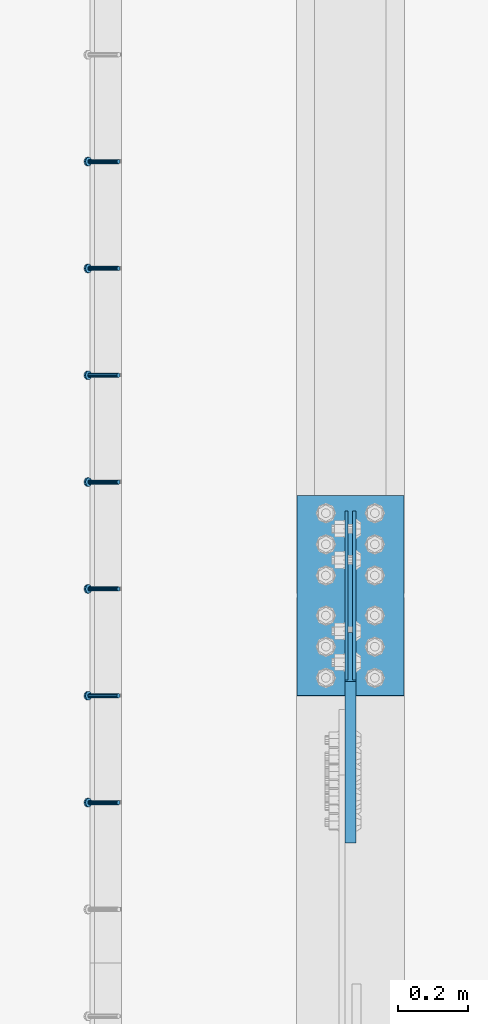
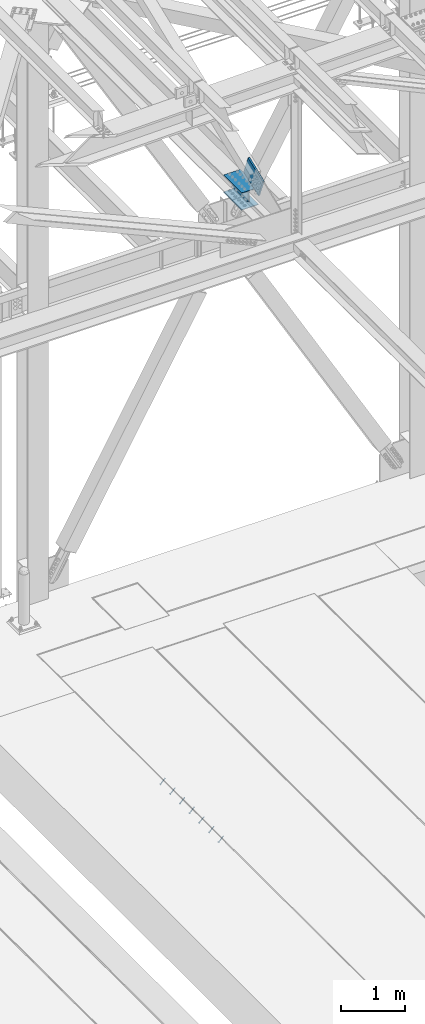
# One storey, part 2482 of 3843: 8 members, 4 beams, 3 elements without a shape of their own.
"""IFC2X3 building model written with IfcOpenShell, lengths in millimetres."""

from ifc_helpers import new_model, si_unit, frame, origin_with_axes, place, context, subcontext, project, spatial, faceted_brep, material, type_object, element, aggregate, save


model = new_model("IFC2X3")

# Units and contexts
model_context = context("Model", 3, precision=1e-05, world=origin_with_axes())
body_context = subcontext(model_context, "Body", "Model", "MODEL_VIEW")
ifc_project = project(units=[si_unit("LENGTHUNIT", "METRE", prefix="MILLI"), si_unit("AREAUNIT", "SQUARE_METRE"), si_unit("VOLUMEUNIT", "CUBIC_METRE"), si_unit("MASSUNIT", "GRAM", prefix="KILO"), si_unit("TIMEUNIT", "SECOND"), si_unit("PLANEANGLEUNIT", "RADIAN"), si_unit("SOLIDANGLEUNIT", "STERADIAN"), si_unit("THERMODYNAMICTEMPERATUREUNIT", "DEGREE_CELSIUS"), si_unit("LUMINOUSINTENSITYUNIT", "LUMEN")], contexts=[model_context])

# Site, building, storey
site_placement = place(None, origin_with_axes())
site = spatial("IfcSite", under=ifc_project, at=site_placement, CompositionType="ELEMENT")
building_placement = place(site_placement, origin_with_axes())
building = spatial("IfcBuilding", under=site, at=building_placement, Name="Undefined", CompositionType="ELEMENT")
storey_placement = place(building_placement, origin_with_axes())
storey = spatial("IfcBuildingStorey", under=building, at=storey_placement, Name="Undefined", CompositionType="ELEMENT", Elevation=0.0)

# Assembly, members
assembly_1_placement = place(storey_placement, origin_with_axes())
assembly_1 = element("IfcElementAssembly", 1, at=assembly_1_placement, inside=storey, Name="EMBED_ANGLE", AssemblyPlace="NOTDEFINED", PredefinedType="RIGID_FRAME")
ifc_material_1 = material(Name="STEEL/A108")
member_type_1 = type_object("IfcMemberType", PredefinedType="NOTDEFINED")
member_1_placement = place(assembly_1_placement, frame((48335.3741210938, 85070.8232116699, 30446.6625), z_axis=(0.0, -1.0, 0.0), x_axis=(-0.707106781186548, 0.0, -0.707106781186548)))
member_1 = element("IfcMember", 2, at=member_1_placement, type_object=member_type_1, material=ifc_material_1, Name="HEADED STUD ANCHOR", context=body_context, shape_type="Brep", body=[
    faceted_brep([(7.27595761418343e-12, -3.18000006675175, 5.5), (0.0, -5.49999999998363, 3.1800000667572), (118.110000000976, -5.49999999999091, 3.1800000667572), (118.110000000983, -3.18000006675175, 5.5), (0.0, -6.3499999046162, 0.0), (118.110000000968, -6.34999990461256, 0.0), (0.0, -5.49999999998363, -3.1800000667572), (118.110000000976, -5.49999999999091, -3.1800000667572), (7.27595761418343e-12, -3.18000006675175, -5.5), (118.110000000983, -3.18000006675175, -5.5), (7.27595761418343e-12, -1.81898940354586e-12, -6.34999990463257), (118.110000000968, -1.81898940354586e-12, -6.34999990463257), (0.0, 3.18000006675175, -5.5), (118.110000000968, 3.18000006674811, -5.5), (7.27595761418343e-12, 5.49999999998363, -3.1800000667572), (118.110000000983, 5.49999999998363, -3.1800000667572), (7.27595761418343e-12, 6.3499999046162, 0.0), (118.110000000976, 6.34999990461256, 0.0), (7.27595761418343e-12, 5.49999999998363, 3.1800000667572), (118.110000000983, 5.49999999998363, 3.1800000667572), (0.0, 3.18000006675175, 5.5), (118.110000000968, 3.18000006674811, 5.5), (7.27595761418343e-12, -1.81898940354586e-12, 6.34999990463257), (118.110000000968, -1.81898940354586e-12, 6.34999990463257), (120.650000000991, -10.9899997710909, 6.34999990463257), (120.650000000998, -6.34000015257152, 10.9899997711182), (120.650000000991, -12.6999998092379, 0.0), (120.650000000991, -10.9899997710909, -6.34999990463257), (120.650000000998, -6.34000015257152, -10.9899997711182), (120.650000000991, -1.81898940354586e-12, -12.6899995803833), (120.650000000991, 6.34000015257152, -10.9899997711182), (120.650000000998, 10.9899997710909, -6.34999990463257), (120.650000000991, 12.6999998092342, 0.0), (120.650000000998, 10.9899997710909, 6.34999990463257), (120.650000000991, 6.34000015257152, 10.9899997711182), (120.650000000991, -1.81898940354586e-12, 12.6899995803833), (127.000000001048, -10.9899997710945, 6.34999990463257), (127.000000001048, -6.34000015257152, 10.9899997711182), (127.000000001048, -12.6999998092342, 0.0), (127.000000001048, -10.9899997710945, -6.34999990463257), (127.000000001048, -6.34000015257152, -10.9899997711182), (127.000000001048, 1.81898940354586e-12, -12.6899995803833), (127.000000001048, 6.34000015256788, -10.9899997711182), (127.000000001048, 10.9899997710909, -6.34999990463257), (127.000000001048, 12.6999998092379, 0.0), (127.000000001048, 10.9899997710909, 6.34999990463257), (127.000000001048, 6.34000015256788, 10.9899997711182), (127.000000001048, 1.81898940354586e-12, 12.6899995803833)], [[[0, 1, 2, 3]], [[1, 4, 5, 2]], [[4, 6, 7, 5]], [[6, 8, 9, 7]], [[8, 10, 11, 9]], [[10, 12, 13, 11]], [[12, 14, 15, 13]], [[14, 16, 17, 15]], [[16, 18, 19, 17]], [[18, 20, 21, 19]], [[20, 22, 23, 21]], [[22, 0, 3, 23]], [[22, 20, 18, 16, 14, 12, 10, 8, 6, 4, 1, 0]], [[3, 2, 24, 25]], [[2, 5, 26, 24]], [[5, 7, 27, 26]], [[7, 9, 28, 27]], [[9, 11, 29, 28]], [[11, 13, 30, 29]], [[13, 15, 31, 30]], [[15, 17, 32, 31]], [[17, 19, 33, 32]], [[19, 21, 34, 33]], [[21, 23, 35, 34]], [[23, 3, 25, 35]], [[25, 24, 36, 37]], [[24, 26, 38, 36]], [[26, 27, 39, 38]], [[27, 28, 40, 39]], [[28, 29, 41, 40]], [[29, 30, 42, 41]], [[30, 31, 43, 42]], [[31, 32, 44, 43]], [[32, 33, 45, 44]], [[33, 34, 46, 45]], [[34, 35, 47, 46]], [[35, 25, 37, 47]], [[38, 39, 40, 41, 42, 43, 44, 45, 46, 47, 37, 36]]]),
])
member_2_placement = place(assembly_1_placement, frame((48335.3741210938, 85375.6232116699, 30446.6625), z_axis=(0.0, -1.0, 0.0), x_axis=(-0.707106781186548, 0.0, -0.707106781186548)))
member_2 = element("IfcMember", 3, at=member_2_placement, type_object=member_type_1, material=ifc_material_1, Name="HEADED STUD ANCHOR", context=body_context, shape_type="Brep", body=[
    faceted_brep([(7.27595761418343e-12, -3.18000006675175, 5.5), (0.0, -5.49999999998363, 3.1800000667572), (118.110000000976, -5.49999999999091, 3.1800000667572), (118.110000000983, -3.18000006675175, 5.5), (0.0, -6.3499999046162, 0.0), (118.110000000968, -6.34999990461256, 0.0), (0.0, -5.49999999998363, -3.1800000667572), (118.110000000976, -5.49999999999091, -3.1800000667572), (7.27595761418343e-12, -3.18000006675175, -5.5), (118.110000000983, -3.18000006675175, -5.5), (7.27595761418343e-12, -1.81898940354586e-12, -6.34999990463257), (118.110000000968, -1.81898940354586e-12, -6.34999990463257), (0.0, 3.18000006675175, -5.5), (118.110000000968, 3.18000006674811, -5.5), (7.27595761418343e-12, 5.49999999998363, -3.1800000667572), (118.110000000983, 5.49999999998363, -3.1800000667572), (7.27595761418343e-12, 6.3499999046162, 0.0), (118.110000000976, 6.34999990461256, 0.0), (7.27595761418343e-12, 5.49999999998363, 3.1800000667572), (118.110000000983, 5.49999999998363, 3.1800000667572), (0.0, 3.18000006675175, 5.5), (118.110000000968, 3.18000006674811, 5.5), (7.27595761418343e-12, -1.81898940354586e-12, 6.34999990463257), (118.110000000968, -1.81898940354586e-12, 6.34999990463257), (120.650000000991, -10.9899997710909, 6.34999990463257), (120.650000000998, -6.34000015257152, 10.9899997711182), (120.650000000991, -12.6999998092379, 0.0), (120.650000000991, -10.9899997710909, -6.34999990463257), (120.650000000998, -6.34000015257152, -10.9899997711182), (120.650000000991, -1.81898940354586e-12, -12.6899995803833), (120.650000000991, 6.34000015257152, -10.9899997711182), (120.650000000998, 10.9899997710909, -6.34999990463257), (120.650000000991, 12.6999998092342, 0.0), (120.650000000998, 10.9899997710909, 6.34999990463257), (120.650000000991, 6.34000015257152, 10.9899997711182), (120.650000000991, -1.81898940354586e-12, 12.6899995803833), (127.000000001048, -10.9899997710945, 6.34999990463257), (127.000000001048, -6.34000015257152, 10.9899997711182), (127.000000001048, -12.6999998092342, 0.0), (127.000000001048, -10.9899997710945, -6.34999990463257), (127.000000001048, -6.34000015257152, -10.9899997711182), (127.000000001048, 1.81898940354586e-12, -12.6899995803833), (127.000000001048, 6.34000015256788, -10.9899997711182), (127.000000001048, 10.9899997710909, -6.34999990463257), (127.000000001048, 12.6999998092379, 0.0), (127.000000001048, 10.9899997710909, 6.34999990463257), (127.000000001048, 6.34000015256788, 10.9899997711182), (127.000000001048, 1.81898940354586e-12, 12.6899995803833)], [[[0, 1, 2, 3]], [[1, 4, 5, 2]], [[4, 6, 7, 5]], [[6, 8, 9, 7]], [[8, 10, 11, 9]], [[10, 12, 13, 11]], [[12, 14, 15, 13]], [[14, 16, 17, 15]], [[16, 18, 19, 17]], [[18, 20, 21, 19]], [[20, 22, 23, 21]], [[22, 0, 3, 23]], [[22, 20, 18, 16, 14, 12, 10, 8, 6, 4, 1, 0]], [[3, 2, 24, 25]], [[2, 5, 26, 24]], [[5, 7, 27, 26]], [[7, 9, 28, 27]], [[9, 11, 29, 28]], [[11, 13, 30, 29]], [[13, 15, 31, 30]], [[15, 17, 32, 31]], [[17, 19, 33, 32]], [[19, 21, 34, 33]], [[21, 23, 35, 34]], [[23, 3, 25, 35]], [[25, 24, 36, 37]], [[24, 26, 38, 36]], [[26, 27, 39, 38]], [[27, 28, 40, 39]], [[28, 29, 41, 40]], [[29, 30, 42, 41]], [[30, 31, 43, 42]], [[31, 32, 44, 43]], [[32, 33, 45, 44]], [[33, 34, 46, 45]], [[34, 35, 47, 46]], [[35, 25, 37, 47]], [[38, 39, 40, 41, 42, 43, 44, 45, 46, 47, 37, 36]]]),
])
member_3_placement = place(assembly_1_placement, frame((48335.3741210938, 85680.4232116699, 30446.6625), z_axis=(0.0, -1.0, 0.0), x_axis=(-0.707106781186548, 0.0, -0.707106781186548)))
member_3 = element("IfcMember", 4, at=member_3_placement, type_object=member_type_1, material=ifc_material_1, Name="HEADED STUD ANCHOR", context=body_context, shape_type="Brep", body=[
    faceted_brep([(7.27595761418343e-12, -3.18000006675175, 5.5), (0.0, -5.49999999998363, 3.1800000667572), (118.110000000976, -5.49999999999091, 3.1800000667572), (118.110000000983, -3.18000006675175, 5.5), (0.0, -6.3499999046162, 0.0), (118.110000000968, -6.34999990461256, 0.0), (0.0, -5.49999999998363, -3.1800000667572), (118.110000000976, -5.49999999999091, -3.1800000667572), (7.27595761418343e-12, -3.18000006675175, -5.5), (118.110000000983, -3.18000006675175, -5.5), (7.27595761418343e-12, -1.81898940354586e-12, -6.34999990463257), (118.110000000968, -1.81898940354586e-12, -6.34999990463257), (0.0, 3.18000006675175, -5.5), (118.110000000968, 3.18000006674811, -5.5), (7.27595761418343e-12, 5.49999999998363, -3.1800000667572), (118.110000000983, 5.49999999998363, -3.1800000667572), (7.27595761418343e-12, 6.3499999046162, 0.0), (118.110000000976, 6.34999990461256, 0.0), (7.27595761418343e-12, 5.49999999998363, 3.1800000667572), (118.110000000983, 5.49999999998363, 3.1800000667572), (0.0, 3.18000006675175, 5.5), (118.110000000968, 3.18000006674811, 5.5), (7.27595761418343e-12, -1.81898940354586e-12, 6.34999990463257), (118.110000000968, -1.81898940354586e-12, 6.34999990463257), (120.650000000991, -10.9899997710909, 6.34999990463257), (120.650000000998, -6.34000015257152, 10.9899997711182), (120.650000000991, -12.6999998092379, 0.0), (120.650000000991, -10.9899997710909, -6.34999990463257), (120.650000000998, -6.34000015257152, -10.9899997711182), (120.650000000991, -1.81898940354586e-12, -12.6899995803833), (120.650000000991, 6.34000015257152, -10.9899997711182), (120.650000000998, 10.9899997710909, -6.34999990463257), (120.650000000991, 12.6999998092342, 0.0), (120.650000000998, 10.9899997710909, 6.34999990463257), (120.650000000991, 6.34000015257152, 10.9899997711182), (120.650000000991, -1.81898940354586e-12, 12.6899995803833), (127.000000001048, -10.9899997710945, 6.34999990463257), (127.000000001048, -6.34000015257152, 10.9899997711182), (127.000000001048, -12.6999998092342, 0.0), (127.000000001048, -10.9899997710945, -6.34999990463257), (127.000000001048, -6.34000015257152, -10.9899997711182), (127.000000001048, 1.81898940354586e-12, -12.6899995803833), (127.000000001048, 6.34000015256788, -10.9899997711182), (127.000000001048, 10.9899997710909, -6.34999990463257), (127.000000001048, 12.6999998092379, 0.0), (127.000000001048, 10.9899997710909, 6.34999990463257), (127.000000001048, 6.34000015256788, 10.9899997711182), (127.000000001048, 1.81898940354586e-12, 12.6899995803833)], [[[0, 1, 2, 3]], [[1, 4, 5, 2]], [[4, 6, 7, 5]], [[6, 8, 9, 7]], [[8, 10, 11, 9]], [[10, 12, 13, 11]], [[12, 14, 15, 13]], [[14, 16, 17, 15]], [[16, 18, 19, 17]], [[18, 20, 21, 19]], [[20, 22, 23, 21]], [[22, 0, 3, 23]], [[22, 20, 18, 16, 14, 12, 10, 8, 6, 4, 1, 0]], [[3, 2, 24, 25]], [[2, 5, 26, 24]], [[5, 7, 27, 26]], [[7, 9, 28, 27]], [[9, 11, 29, 28]], [[11, 13, 30, 29]], [[13, 15, 31, 30]], [[15, 17, 32, 31]], [[17, 19, 33, 32]], [[19, 21, 34, 33]], [[21, 23, 35, 34]], [[23, 3, 25, 35]], [[25, 24, 36, 37]], [[24, 26, 38, 36]], [[26, 27, 39, 38]], [[27, 28, 40, 39]], [[28, 29, 41, 40]], [[29, 30, 42, 41]], [[30, 31, 43, 42]], [[31, 32, 44, 43]], [[32, 33, 45, 44]], [[33, 34, 46, 45]], [[34, 35, 47, 46]], [[35, 25, 37, 47]], [[38, 39, 40, 41, 42, 43, 44, 45, 46, 47, 37, 36]]]),
])
member_4_placement = place(assembly_1_placement, frame((48335.3741210938, 85985.2232116699, 30446.6625), z_axis=(0.0, -1.0, 0.0), x_axis=(-0.707106781186548, 0.0, -0.707106781186548)))
member_4 = element("IfcMember", 5, at=member_4_placement, type_object=member_type_1, material=ifc_material_1, Name="HEADED STUD ANCHOR", context=body_context, shape_type="Brep", body=[
    faceted_brep([(7.27595761418343e-12, -3.18000006675175, 5.5), (0.0, -5.49999999998363, 3.1800000667572), (118.110000000976, -5.49999999999091, 3.1800000667572), (118.110000000983, -3.18000006675175, 5.5), (0.0, -6.3499999046162, 0.0), (118.110000000968, -6.34999990461256, 0.0), (0.0, -5.49999999998363, -3.1800000667572), (118.110000000976, -5.49999999999091, -3.1800000667572), (7.27595761418343e-12, -3.18000006675175, -5.5), (118.110000000983, -3.18000006675175, -5.5), (7.27595761418343e-12, -1.81898940354586e-12, -6.34999990463257), (118.110000000968, -1.81898940354586e-12, -6.34999990463257), (0.0, 3.18000006675175, -5.5), (118.110000000968, 3.18000006674811, -5.5), (7.27595761418343e-12, 5.49999999998363, -3.1800000667572), (118.110000000983, 5.49999999998363, -3.1800000667572), (7.27595761418343e-12, 6.3499999046162, 0.0), (118.110000000976, 6.34999990461256, 0.0), (7.27595761418343e-12, 5.49999999998363, 3.1800000667572), (118.110000000983, 5.49999999998363, 3.1800000667572), (0.0, 3.18000006675175, 5.5), (118.110000000968, 3.18000006674811, 5.5), (7.27595761418343e-12, -1.81898940354586e-12, 6.34999990463257), (118.110000000968, -1.81898940354586e-12, 6.34999990463257), (120.650000000991, -10.9899997710909, 6.34999990463257), (120.650000000998, -6.34000015257152, 10.9899997711182), (120.650000000991, -12.6999998092379, 0.0), (120.650000000991, -10.9899997710909, -6.34999990463257), (120.650000000998, -6.34000015257152, -10.9899997711182), (120.650000000991, -1.81898940354586e-12, -12.6899995803833), (120.650000000991, 6.34000015257152, -10.9899997711182), (120.650000000998, 10.9899997710909, -6.34999990463257), (120.650000000991, 12.6999998092342, 0.0), (120.650000000998, 10.9899997710909, 6.34999990463257), (120.650000000991, 6.34000015257152, 10.9899997711182), (120.650000000991, -1.81898940354586e-12, 12.6899995803833), (127.000000001048, -10.9899997710945, 6.34999990463257), (127.000000001048, -6.34000015257152, 10.9899997711182), (127.000000001048, -12.6999998092342, 0.0), (127.000000001048, -10.9899997710945, -6.34999990463257), (127.000000001048, -6.34000015257152, -10.9899997711182), (127.000000001048, 1.81898940354586e-12, -12.6899995803833), (127.000000001048, 6.34000015256788, -10.9899997711182), (127.000000001048, 10.9899997710909, -6.34999990463257), (127.000000001048, 12.6999998092379, 0.0), (127.000000001048, 10.9899997710909, 6.34999990463257), (127.000000001048, 6.34000015256788, 10.9899997711182), (127.000000001048, 1.81898940354586e-12, 12.6899995803833)], [[[0, 1, 2, 3]], [[1, 4, 5, 2]], [[4, 6, 7, 5]], [[6, 8, 9, 7]], [[8, 10, 11, 9]], [[10, 12, 13, 11]], [[12, 14, 15, 13]], [[14, 16, 17, 15]], [[16, 18, 19, 17]], [[18, 20, 21, 19]], [[20, 22, 23, 21]], [[22, 0, 3, 23]], [[22, 20, 18, 16, 14, 12, 10, 8, 6, 4, 1, 0]], [[3, 2, 24, 25]], [[2, 5, 26, 24]], [[5, 7, 27, 26]], [[7, 9, 28, 27]], [[9, 11, 29, 28]], [[11, 13, 30, 29]], [[13, 15, 31, 30]], [[15, 17, 32, 31]], [[17, 19, 33, 32]], [[19, 21, 34, 33]], [[21, 23, 35, 34]], [[23, 3, 25, 35]], [[25, 24, 36, 37]], [[24, 26, 38, 36]], [[26, 27, 39, 38]], [[27, 28, 40, 39]], [[28, 29, 41, 40]], [[29, 30, 42, 41]], [[30, 31, 43, 42]], [[31, 32, 44, 43]], [[32, 33, 45, 44]], [[33, 34, 46, 45]], [[34, 35, 47, 46]], [[35, 25, 37, 47]], [[38, 39, 40, 41, 42, 43, 44, 45, 46, 47, 37, 36]]]),
])
member_5_placement = place(assembly_1_placement, frame((48335.3741210938, 86290.0232116699, 30446.6625), z_axis=(0.0, -1.0, 0.0), x_axis=(-0.707106781186548, 0.0, -0.707106781186548)))
member_5 = element("IfcMember", 6, at=member_5_placement, type_object=member_type_1, material=ifc_material_1, Name="HEADED STUD ANCHOR", context=body_context, shape_type="Brep", body=[
    faceted_brep([(7.27595761418343e-12, -3.18000006675175, 5.5), (0.0, -5.49999999998363, 3.1800000667572), (118.110000000976, -5.49999999999091, 3.1800000667572), (118.110000000983, -3.18000006675175, 5.5), (0.0, -6.3499999046162, 0.0), (118.110000000968, -6.34999990461256, 0.0), (0.0, -5.49999999998363, -3.1800000667572), (118.110000000976, -5.49999999999091, -3.1800000667572), (7.27595761418343e-12, -3.18000006675175, -5.5), (118.110000000983, -3.18000006675175, -5.5), (7.27595761418343e-12, -1.81898940354586e-12, -6.34999990463257), (118.110000000968, -1.81898940354586e-12, -6.34999990463257), (0.0, 3.18000006675175, -5.5), (118.110000000968, 3.18000006674811, -5.5), (7.27595761418343e-12, 5.49999999998363, -3.1800000667572), (118.110000000983, 5.49999999998363, -3.1800000667572), (7.27595761418343e-12, 6.3499999046162, 0.0), (118.110000000976, 6.34999990461256, 0.0), (7.27595761418343e-12, 5.49999999998363, 3.1800000667572), (118.110000000983, 5.49999999998363, 3.1800000667572), (0.0, 3.18000006675175, 5.5), (118.110000000968, 3.18000006674811, 5.5), (7.27595761418343e-12, -1.81898940354586e-12, 6.34999990463257), (118.110000000968, -1.81898940354586e-12, 6.34999990463257), (120.650000000991, -10.9899997710909, 6.34999990463257), (120.650000000998, -6.34000015257152, 10.9899997711182), (120.650000000991, -12.6999998092379, 0.0), (120.650000000991, -10.9899997710909, -6.34999990463257), (120.650000000998, -6.34000015257152, -10.9899997711182), (120.650000000991, -1.81898940354586e-12, -12.6899995803833), (120.650000000991, 6.34000015257152, -10.9899997711182), (120.650000000998, 10.9899997710909, -6.34999990463257), (120.650000000991, 12.6999998092342, 0.0), (120.650000000998, 10.9899997710909, 6.34999990463257), (120.650000000991, 6.34000015257152, 10.9899997711182), (120.650000000991, -1.81898940354586e-12, 12.6899995803833), (127.000000001048, -10.9899997710945, 6.34999990463257), (127.000000001048, -6.34000015257152, 10.9899997711182), (127.000000001048, -12.6999998092342, 0.0), (127.000000001048, -10.9899997710945, -6.34999990463257), (127.000000001048, -6.34000015257152, -10.9899997711182), (127.000000001048, 1.81898940354586e-12, -12.6899995803833), (127.000000001048, 6.34000015256788, -10.9899997711182), (127.000000001048, 10.9899997710909, -6.34999990463257), (127.000000001048, 12.6999998092379, 0.0), (127.000000001048, 10.9899997710909, 6.34999990463257), (127.000000001048, 6.34000015256788, 10.9899997711182), (127.000000001048, 1.81898940354586e-12, 12.6899995803833)], [[[0, 1, 2, 3]], [[1, 4, 5, 2]], [[4, 6, 7, 5]], [[6, 8, 9, 7]], [[8, 10, 11, 9]], [[10, 12, 13, 11]], [[12, 14, 15, 13]], [[14, 16, 17, 15]], [[16, 18, 19, 17]], [[18, 20, 21, 19]], [[20, 22, 23, 21]], [[22, 0, 3, 23]], [[22, 20, 18, 16, 14, 12, 10, 8, 6, 4, 1, 0]], [[3, 2, 24, 25]], [[2, 5, 26, 24]], [[5, 7, 27, 26]], [[7, 9, 28, 27]], [[9, 11, 29, 28]], [[11, 13, 30, 29]], [[13, 15, 31, 30]], [[15, 17, 32, 31]], [[17, 19, 33, 32]], [[19, 21, 34, 33]], [[21, 23, 35, 34]], [[23, 3, 25, 35]], [[25, 24, 36, 37]], [[24, 26, 38, 36]], [[26, 27, 39, 38]], [[27, 28, 40, 39]], [[28, 29, 41, 40]], [[29, 30, 42, 41]], [[30, 31, 43, 42]], [[31, 32, 44, 43]], [[32, 33, 45, 44]], [[33, 34, 46, 45]], [[34, 35, 47, 46]], [[35, 25, 37, 47]], [[38, 39, 40, 41, 42, 43, 44, 45, 46, 47, 37, 36]]]),
])
member_6_placement = place(assembly_1_placement, frame((48335.3741210938, 86594.8232116699, 30446.6625), z_axis=(0.0, -1.0, 0.0), x_axis=(-0.707106781186548, 0.0, -0.707106781186548)))
member_6 = element("IfcMember", 7, at=member_6_placement, type_object=member_type_1, material=ifc_material_1, Name="HEADED STUD ANCHOR", context=body_context, shape_type="Brep", body=[
    faceted_brep([(7.27595761418343e-12, -3.18000006675175, 5.5), (0.0, -5.49999999998363, 3.1800000667572), (118.110000000976, -5.49999999999091, 3.1800000667572), (118.110000000983, -3.18000006675175, 5.5), (0.0, -6.3499999046162, 0.0), (118.110000000968, -6.34999990461256, 0.0), (0.0, -5.49999999998363, -3.1800000667572), (118.110000000976, -5.49999999999091, -3.1800000667572), (7.27595761418343e-12, -3.18000006675175, -5.5), (118.110000000983, -3.18000006675175, -5.5), (7.27595761418343e-12, -1.81898940354586e-12, -6.34999990463257), (118.110000000968, -1.81898940354586e-12, -6.34999990463257), (0.0, 3.18000006675175, -5.5), (118.110000000968, 3.18000006674811, -5.5), (7.27595761418343e-12, 5.49999999998363, -3.1800000667572), (118.110000000983, 5.49999999998363, -3.1800000667572), (7.27595761418343e-12, 6.3499999046162, 0.0), (118.110000000976, 6.34999990461256, 0.0), (7.27595761418343e-12, 5.49999999998363, 3.1800000667572), (118.110000000983, 5.49999999998363, 3.1800000667572), (0.0, 3.18000006675175, 5.5), (118.110000000968, 3.18000006674811, 5.5), (7.27595761418343e-12, -1.81898940354586e-12, 6.34999990463257), (118.110000000968, -1.81898940354586e-12, 6.34999990463257), (120.650000000991, -10.9899997710909, 6.34999990463257), (120.650000000998, -6.34000015257152, 10.9899997711182), (120.650000000991, -12.6999998092379, 0.0), (120.650000000991, -10.9899997710909, -6.34999990463257), (120.650000000998, -6.34000015257152, -10.9899997711182), (120.650000000991, -1.81898940354586e-12, -12.6899995803833), (120.650000000991, 6.34000015257152, -10.9899997711182), (120.650000000998, 10.9899997710909, -6.34999990463257), (120.650000000991, 12.6999998092342, 0.0), (120.650000000998, 10.9899997710909, 6.34999990463257), (120.650000000991, 6.34000015257152, 10.9899997711182), (120.650000000991, -1.81898940354586e-12, 12.6899995803833), (127.000000001048, -10.9899997710945, 6.34999990463257), (127.000000001048, -6.34000015257152, 10.9899997711182), (127.000000001048, -12.6999998092342, 0.0), (127.000000001048, -10.9899997710945, -6.34999990463257), (127.000000001048, -6.34000015257152, -10.9899997711182), (127.000000001048, 1.81898940354586e-12, -12.6899995803833), (127.000000001048, 6.34000015256788, -10.9899997711182), (127.000000001048, 10.9899997710909, -6.34999990463257), (127.000000001048, 12.6999998092379, 0.0), (127.000000001048, 10.9899997710909, 6.34999990463257), (127.000000001048, 6.34000015256788, 10.9899997711182), (127.000000001048, 1.81898940354586e-12, 12.6899995803833)], [[[0, 1, 2, 3]], [[1, 4, 5, 2]], [[4, 6, 7, 5]], [[6, 8, 9, 7]], [[8, 10, 11, 9]], [[10, 12, 13, 11]], [[12, 14, 15, 13]], [[14, 16, 17, 15]], [[16, 18, 19, 17]], [[18, 20, 21, 19]], [[20, 22, 23, 21]], [[22, 0, 3, 23]], [[22, 20, 18, 16, 14, 12, 10, 8, 6, 4, 1, 0]], [[3, 2, 24, 25]], [[2, 5, 26, 24]], [[5, 7, 27, 26]], [[7, 9, 28, 27]], [[9, 11, 29, 28]], [[11, 13, 30, 29]], [[13, 15, 31, 30]], [[15, 17, 32, 31]], [[17, 19, 33, 32]], [[19, 21, 34, 33]], [[21, 23, 35, 34]], [[23, 3, 25, 35]], [[25, 24, 36, 37]], [[24, 26, 38, 36]], [[26, 27, 39, 38]], [[27, 28, 40, 39]], [[28, 29, 41, 40]], [[29, 30, 42, 41]], [[30, 31, 43, 42]], [[31, 32, 44, 43]], [[32, 33, 45, 44]], [[33, 34, 46, 45]], [[34, 35, 47, 46]], [[35, 25, 37, 47]], [[38, 39, 40, 41, 42, 43, 44, 45, 46, 47, 37, 36]]]),
])
member_7_placement = place(assembly_1_placement, frame((48335.3741210938, 86899.6232116699, 30446.6625), z_axis=(0.0, -1.0, 0.0), x_axis=(-0.707106781186548, 0.0, -0.707106781186548)))
member_7 = element("IfcMember", 8, at=member_7_placement, type_object=member_type_1, material=ifc_material_1, Name="HEADED STUD ANCHOR", context=body_context, shape_type="Brep", body=[
    faceted_brep([(7.27595761418343e-12, -3.18000006675175, 5.5), (0.0, -5.49999999998363, 3.1800000667572), (118.110000000976, -5.49999999999091, 3.1800000667572), (118.110000000983, -3.18000006675175, 5.5), (0.0, -6.3499999046162, 0.0), (118.110000000968, -6.34999990461256, 0.0), (0.0, -5.49999999998363, -3.1800000667572), (118.110000000976, -5.49999999999091, -3.1800000667572), (7.27595761418343e-12, -3.18000006675175, -5.5), (118.110000000983, -3.18000006675175, -5.5), (7.27595761418343e-12, -1.81898940354586e-12, -6.34999990463257), (118.110000000968, -1.81898940354586e-12, -6.34999990463257), (0.0, 3.18000006675175, -5.5), (118.110000000968, 3.18000006674811, -5.5), (7.27595761418343e-12, 5.49999999998363, -3.1800000667572), (118.110000000983, 5.49999999998363, -3.1800000667572), (7.27595761418343e-12, 6.3499999046162, 0.0), (118.110000000976, 6.34999990461256, 0.0), (7.27595761418343e-12, 5.49999999998363, 3.1800000667572), (118.110000000983, 5.49999999998363, 3.1800000667572), (0.0, 3.18000006675175, 5.5), (118.110000000968, 3.18000006674811, 5.5), (7.27595761418343e-12, -1.81898940354586e-12, 6.34999990463257), (118.110000000968, -1.81898940354586e-12, 6.34999990463257), (120.650000000991, -10.9899997710909, 6.34999990463257), (120.650000000998, -6.34000015257152, 10.9899997711182), (120.650000000991, -12.6999998092379, 0.0), (120.650000000991, -10.9899997710909, -6.34999990463257), (120.650000000998, -6.34000015257152, -10.9899997711182), (120.650000000991, -1.81898940354586e-12, -12.6899995803833), (120.650000000991, 6.34000015257152, -10.9899997711182), (120.650000000998, 10.9899997710909, -6.34999990463257), (120.650000000991, 12.6999998092342, 0.0), (120.650000000998, 10.9899997710909, 6.34999990463257), (120.650000000991, 6.34000015257152, 10.9899997711182), (120.650000000991, -1.81898940354586e-12, 12.6899995803833), (127.000000001048, -10.9899997710945, 6.34999990463257), (127.000000001048, -6.34000015257152, 10.9899997711182), (127.000000001048, -12.6999998092342, 0.0), (127.000000001048, -10.9899997710945, -6.34999990463257), (127.000000001048, -6.34000015257152, -10.9899997711182), (127.000000001048, 1.81898940354586e-12, -12.6899995803833), (127.000000001048, 6.34000015256788, -10.9899997711182), (127.000000001048, 10.9899997710909, -6.34999990463257), (127.000000001048, 12.6999998092379, 0.0), (127.000000001048, 10.9899997710909, 6.34999990463257), (127.000000001048, 6.34000015256788, 10.9899997711182), (127.000000001048, 1.81898940354586e-12, 12.6899995803833)], [[[0, 1, 2, 3]], [[1, 4, 5, 2]], [[4, 6, 7, 5]], [[6, 8, 9, 7]], [[8, 10, 11, 9]], [[10, 12, 13, 11]], [[12, 14, 15, 13]], [[14, 16, 17, 15]], [[16, 18, 19, 17]], [[18, 20, 21, 19]], [[20, 22, 23, 21]], [[22, 0, 3, 23]], [[22, 20, 18, 16, 14, 12, 10, 8, 6, 4, 1, 0]], [[3, 2, 24, 25]], [[2, 5, 26, 24]], [[5, 7, 27, 26]], [[7, 9, 28, 27]], [[9, 11, 29, 28]], [[11, 13, 30, 29]], [[13, 15, 31, 30]], [[15, 17, 32, 31]], [[17, 19, 33, 32]], [[19, 21, 34, 33]], [[21, 23, 35, 34]], [[23, 3, 25, 35]], [[25, 24, 36, 37]], [[24, 26, 38, 36]], [[26, 27, 39, 38]], [[27, 28, 40, 39]], [[28, 29, 41, 40]], [[29, 30, 42, 41]], [[30, 31, 43, 42]], [[31, 32, 44, 43]], [[32, 33, 45, 44]], [[33, 34, 46, 45]], [[34, 35, 47, 46]], [[35, 25, 37, 47]], [[38, 39, 40, 41, 42, 43, 44, 45, 46, 47, 37, 36]]]),
])
aggregate(assembly_1, [member_1, member_2, member_3, member_4, member_5, member_6, member_7])

# Assembly, beams
assembly_2_placement = place(storey_placement, origin_with_axes())
assembly_2 = element("IfcElementAssembly", 9, at=assembly_2_placement, inside=storey, Name="BEAM", AssemblyPlace="NOTDEFINED", PredefinedType="RIGID_FRAME")
ifc_material_2 = material(Name="STEEL/A572-50")
beam_type_1 = type_object("IfcBeamType", PredefinedType="NOTDEFINED")
beam_1_placement = place(assembly_2_placement, frame((49007.7125, 85420.2000640877, 42251.5011023711), z_axis=(0.0, 0.00072869199964043, 0.99999973450395), x_axis=(0.0, 0.99999973450395, -0.000728691999638273)))
beam_1 = element("IfcBeam", 10, at=beam_1_placement, type_object=beam_type_1, material=ifc_material_2, Name="PLATE", context=body_context, shape_type="Brep", body=[
    faceted_brep([(-4.65661287307739e-10, 4.76249999999709, -88.9000000002779), (0.0, 4.76249999999709, 88.9000015258789), (482.600000007384, 4.76249999999709, 88.9000000010856), (482.60000000638, 4.76249999999709, -88.8999999994776), (0.0, -4.76249999999709, 88.9000015258789), (482.600000007384, -4.76249999999709, 88.9000000010856), (-4.65661287307739e-10, -4.76249999999709, -88.9000000002779), (482.60000000638, -4.76249999999709, -88.8999999994776)], [[[0, 1, 2, 3]], [[1, 4, 5, 2]], [[4, 6, 7, 5]], [[6, 0, 3, 7]], [[5, 7, 3, 2]], [[6, 4, 1, 0]]]),
])
beam_2_placement = place(assembly_2_placement, frame((48985.4875, 85420.2000640877, 42251.5011023711), z_axis=(0.0, 0.00072869199964043, 0.99999973450395), x_axis=(0.0, 0.99999973450395, -0.000728691999638273)))
beam_2 = element("IfcBeam", 11, at=beam_2_placement, type_object=beam_type_1, material=ifc_material_2, Name="PLATE", context=body_context, shape_type="Brep", body=[
    faceted_brep([(-4.65661287307739e-10, 4.76249999999709, -88.9000000002779), (0.0, 4.76249999999709, 88.9000015258789), (482.600000007384, 4.76249999999709, 88.9000000010856), (482.60000000638, 4.76249999999709, -88.8999999994776), (0.0, -4.76249999999709, 88.9000015258789), (482.600000007384, -4.76249999999709, 88.9000000010856), (-4.65661287307739e-10, -4.76249999999709, -88.9000000002779), (482.60000000638, -4.76249999999709, -88.8999999994776)], [[[0, 1, 2, 3]], [[1, 4, 5, 2]], [[4, 6, 7, 5]], [[6, 0, 3, 7]], [[5, 7, 3, 2]], [[6, 4, 1, 0]]]),
])
beam_type_2 = type_object("IfcBeamType", PredefinedType="NOTDEFINED")
beam_3_placement = place(assembly_2_placement, frame((48996.6, 85375.6320824378, 42089.6085357147), z_axis=(1.0, 0.0, 0.0), x_axis=(0.0, 0.99999973450395, -0.000728691999638273)))
beam_3 = element("IfcBeam", 12, at=beam_3_placement, type_object=beam_type_2, material=ifc_material_2, Name="PLATE", context=body_context, shape_type="Brep", body=[
    faceted_brep([(2.91038304567337e-11, 4.76250000001892, -152.400000000001), (2.91038304567337e-11, 4.76250000001892, 152.400000000001), (571.500000008222, 4.76250000096479, 152.400000000001), (571.500000008222, 4.76250000096479, -152.400000000001), (-2.91038304567337e-11, -4.76250000001164, 152.400000000001), (571.500000008164, -4.76249999906577, 152.400000000001), (-2.91038304567337e-11, -4.76250000001164, -152.400000000001), (571.500000008164, -4.76249999906577, -152.400000000001)], [[[0, 1, 2, 3]], [[1, 4, 5, 2]], [[4, 6, 7, 5]], [[6, 0, 3, 7]], [[5, 7, 3, 2]], [[6, 4, 1, 0]]]),
])
beam_4_placement = place(assembly_2_placement, frame((48996.6, 85375.8680693423, 42413.4584497465), z_axis=(1.0, 0.0, 0.0), x_axis=(0.0, 0.99999973450395, -0.000728691999638273)))
beam_4 = element("IfcBeam", 13, at=beam_4_placement, type_object=beam_type_2, material=ifc_material_2, Name="PLATE", context=body_context, shape_type="Brep", body=[
    faceted_brep([(2.91038304567337e-11, 4.76250000001892, -152.400000000001), (2.91038304567337e-11, 4.76250000001892, 152.400000000001), (571.500000008222, 4.76250000096479, 152.400000000001), (571.500000008222, 4.76250000096479, -152.400000000001), (-2.91038304567337e-11, -4.76250000001164, 152.400000000001), (571.500000008164, -4.76249999906577, 152.400000000001), (-2.91038304567337e-11, -4.76250000001164, -152.400000000001), (571.500000008164, -4.76249999906577, -152.400000000001)], [[[0, 1, 2, 3]], [[1, 4, 5, 2]], [[4, 6, 7, 5]], [[6, 0, 3, 7]], [[5, 7, 3, 2]], [[6, 4, 1, 0]]]),
])
aggregate(assembly_2, [beam_1, beam_3, beam_4, beam_2])

# Assembly, member
assembly_3_placement = place(storey_placement, origin_with_axes())
assembly_3 = element("IfcElementAssembly", 14, at=assembly_3_placement, inside=storey, AssemblyPlace="NOTDEFINED", PredefinedType="RIGID_FRAME")
member_type_2 = type_object("IfcMemberType", PredefinedType="NOTDEFINED")
member_8_placement = place(assembly_3_placement, frame((48996.6, 85025.717032858, 42661.9484392652), z_axis=(0.0, 0.366107652881547, -0.93057250469889), x_axis=(0.0, 0.930572504698894, 0.366107652881536)))
member_8 = element("IfcMember", 15, at=member_8_placement, type_object=member_type_2, material=ifc_material_2, Name="PLATE", context=body_context, shape_type="Brep", body=[
    faceted_brep([(3.56521923094988e-10, 15.875, -190.500000000146), (-3.61978891305625e-10, 15.875, 190.500000000153), (495.299999995012, 15.875, 190.500000001084), (495.299999995726, 15.875, -190.499999999221), (-3.61978891305625e-10, -15.875, 190.500000000153), (495.299999995012, -15.875, 190.500000001084), (3.56521923094988e-10, -15.875, -190.500000000146), (495.299999995726, -15.875, -190.499999999221)], [[[0, 1, 2, 3]], [[1, 4, 5, 2]], [[4, 6, 7, 5]], [[6, 0, 3, 7]], [[5, 7, 3, 2]], [[6, 4, 1, 0]]]),
])
aggregate(assembly_3, [member_8])

save(model, "model.ifc")
